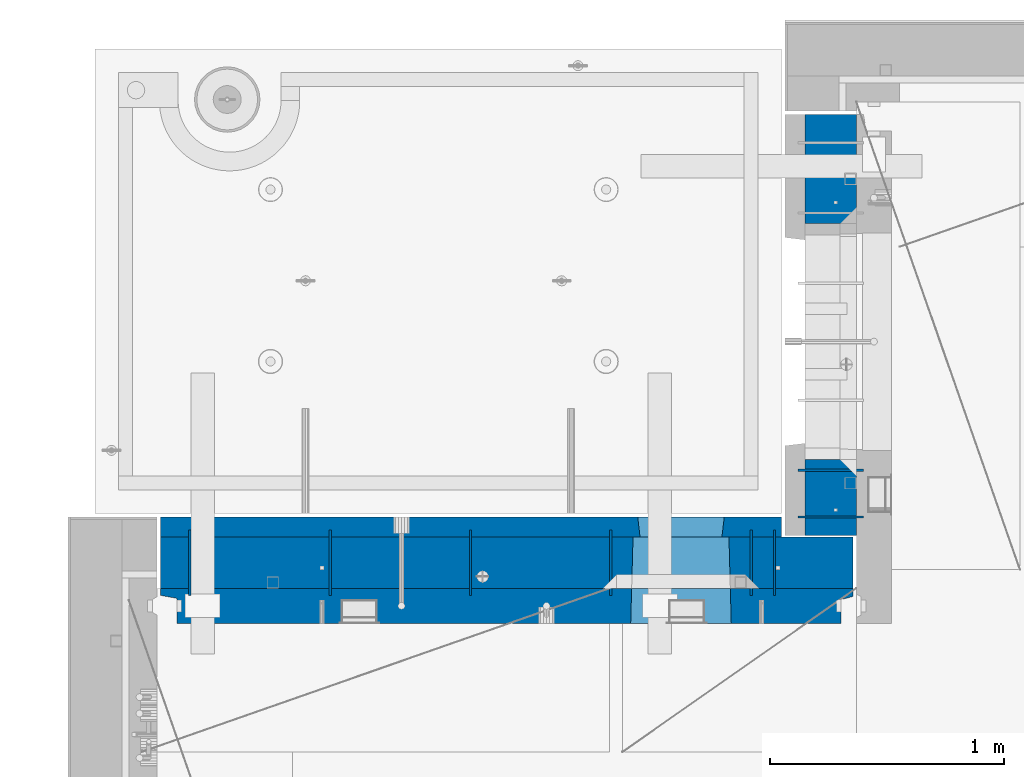
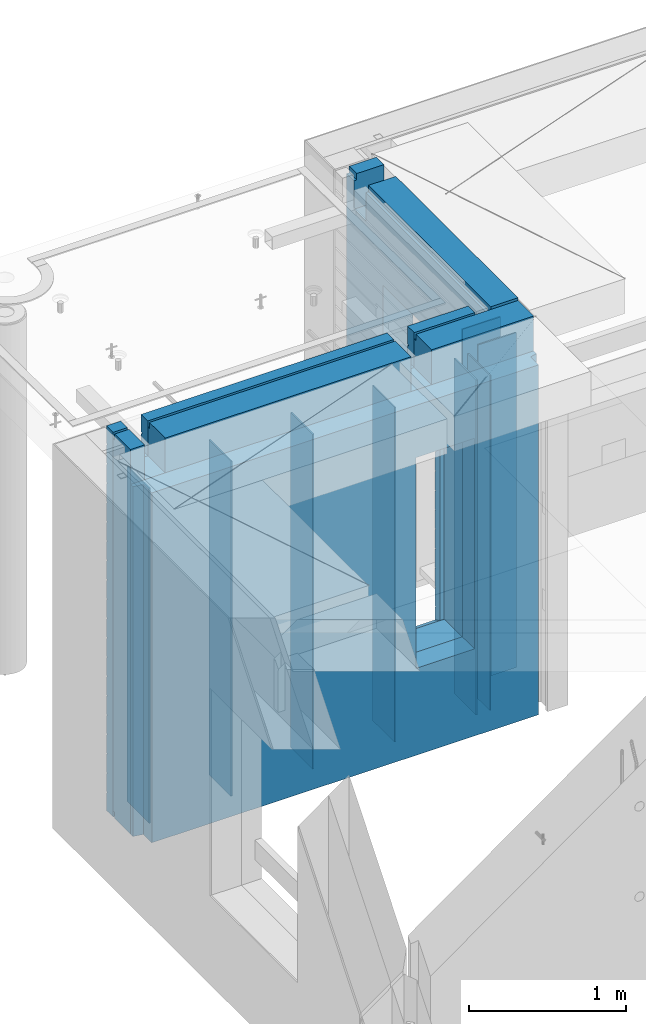
# One storey, part 236 of 350: 12 walls, 2 elements without a shape of their own.
"""IFC2X3 building model written with IfcOpenShell, lengths in millimetres."""

from ifc_helpers import new_model, si_unit, frame, origin_with_axes, place, context, subcontext, project, spatial, faceted_brep, material, type_object, element, aggregate, save


model = new_model("IFC2X3")

# Units and contexts
model_context = context("Model", 3, precision=1e-05, world=origin_with_axes())
body_context = subcontext(model_context, "Body", "Model", "MODEL_VIEW")
ifc_project = project(units=[si_unit("LENGTHUNIT", "METRE", prefix="MILLI"), si_unit("AREAUNIT", "SQUARE_METRE"), si_unit("VOLUMEUNIT", "CUBIC_METRE"), si_unit("MASSUNIT", "GRAM", prefix="KILO"), si_unit("TIMEUNIT", "SECOND"), si_unit("PLANEANGLEUNIT", "RADIAN"), si_unit("SOLIDANGLEUNIT", "STERADIAN"), si_unit("THERMODYNAMICTEMPERATUREUNIT", "DEGREE_CELSIUS"), si_unit("LUMINOUSINTENSITYUNIT", "LUMEN")], contexts=[model_context])

# Site, building, storey
site_placement = place(None, origin_with_axes())
site = spatial("IfcSite", under=ifc_project, at=site_placement, CompositionType="ELEMENT")
building_placement = place(site_placement, origin_with_axes())
building = spatial("IfcBuilding", under=site, at=building_placement, CompositionType="ELEMENT")
storey_placement = place(building_placement, origin_with_axes())
storey = spatial("IfcBuildingStorey", under=building, at=storey_placement, Name="2", CompositionType="ELEMENT", Elevation=0.0)

# Assembly, wall
assembly_1_placement = place(storey_placement, origin_with_axes())
assembly_1 = element("IfcElementAssembly", 1, at=assembly_1_placement, inside=storey, AssemblyPlace="NOTDEFINED", PredefinedType="REINFORCEMENT_UNIT")
ifc_material_1 = material(Name="Undefined")
wall_type_1 = type_object("IfcWallType", PredefinedType="NOTDEFINED")
wall_1_placement = place(assembly_1_placement, frame((11020.0, 20885.0002441406, 86115.0), z_axis=(0.0, 0.0, 1.0), x_axis=(-1.0, 3.00000001838171e-08, 0.0)))
wall_1 = element("IfcWall", 2, at=wall_1_placement, type_object=wall_type_1, material=ifc_material_1, Name="(PD)", context=body_context, shape_type="Brep", body=[
    faceted_brep([(0.0, 5.0, -1300.0), (0.0, 5.0, 1300.0), (280.0, 5.0, 1300.0), (280.0, 5.0, -1300.0), (0.0, -5.0, 1300.0), (280.0, -5.0, 1300.0), (0.0, -5.0, -1300.0), (280.0, -5.0, -1300.0)], [[[0, 1, 2, 3]], [[1, 4, 5, 2]], [[4, 6, 7, 5]], [[6, 0, 3, 7]], [[5, 7, 3, 2]], [[6, 4, 1, 0]]]),
])

assembly_2_placement = place(storey_placement, origin_with_axes())
assembly_2 = element("IfcElementAssembly", 3, at=assembly_2_placement, inside=storey, AssemblyPlace="NOTDEFINED", PredefinedType="REINFORCEMENT_UNIT")
wall_2_placement = place(assembly_2_placement, frame((10640.0002441406, 20549.9951872276, 86115.0), z_axis=(0.0, 0.0, 1.0), x_axis=(0.0, 1.0, 0.0)))
wall_2 = element("IfcWall", 4, at=wall_2_placement, type_object=wall_type_1, material=ifc_material_1, Name="(PD)", context=body_context, shape_type="Brep", body=[
    faceted_brep([(0.0, 5.0, -1300.0), (0.0, 5.0, 1300.0), (280.0, 5.0, 1300.0), (280.0, 5.0, -1300.0), (0.0, -5.0, 1300.0), (280.0, -5.0, 1300.0), (0.0, -5.0, -1300.0), (280.0, -5.0, -1300.0)], [[[0, 1, 2, 3]], [[1, 4, 5, 2]], [[4, 6, 7, 5]], [[6, 0, 3, 7]], [[5, 7, 3, 2]], [[6, 4, 1, 0]]]),
])

# Wall
wall_3_placement = place(assembly_1_placement, frame((11020.0, 21085.0002441406, 86115.0), z_axis=(0.0, 0.0, 1.0), x_axis=(-1.0, 3.00000001838171e-08, 0.0)))
wall_3 = element("IfcWall", 5, at=wall_3_placement, type_object=wall_type_1, material=ifc_material_1, Name="(PD)", context=body_context, shape_type="Brep", body=[
    faceted_brep([(0.0, 5.0, -1300.0), (0.0, 5.0, 1300.0), (280.0, 5.0, 1300.0), (280.0, 5.0, -1300.0), (0.0, -5.0, 1300.0), (280.0, -5.0, 1300.0), (0.0, -5.0, -1300.0), (280.0, -5.0, -1300.0)], [[[0, 1, 2, 3]], [[1, 4, 5, 2]], [[4, 6, 7, 5]], [[6, 0, 3, 7]], [[5, 7, 3, 2]], [[6, 4, 1, 0]]]),
])

wall_4_placement = place(assembly_2_placement, frame((8140.00024414063, 20549.9951872276, 86115.0), z_axis=(0.0, 0.0, 1.0), x_axis=(0.0, 1.0, 0.0)))
wall_4 = element("IfcWall", 6, at=wall_4_placement, type_object=wall_type_1, material=ifc_material_1, Name="(PD)", context=body_context, shape_type="Brep", body=[
    faceted_brep([(0.0, 5.0, -1300.0), (0.0, 5.0, 1300.0), (280.0, 5.0, 1300.0), (280.0, 5.0, -1300.0), (0.0, -5.0, 1300.0), (280.0, -5.0, 1300.0), (0.0, -5.0, -1300.0), (280.0, -5.0, -1300.0)], [[[0, 1, 2, 3]], [[1, 4, 5, 2]], [[4, 6, 7, 5]], [[6, 0, 3, 7]], [[5, 7, 3, 2]], [[6, 4, 1, 0]]]),
])

wall_5_placement = place(assembly_2_placement, frame((8740.00024414063, 20549.9951872276, 86115.0), z_axis=(0.0, 0.0, 1.0), x_axis=(0.0, 1.0, 0.0)))
wall_5 = element("IfcWall", 7, at=wall_5_placement, type_object=wall_type_1, material=ifc_material_1, Name="(PD)", context=body_context, shape_type="Brep", body=[
    faceted_brep([(0.0, 5.0, -1300.0), (0.0, 5.0, 1300.0), (280.0, 5.0, 1300.0), (280.0, 5.0, -1300.0), (0.0, -5.0, 1300.0), (280.0, -5.0, 1300.0), (0.0, -5.0, -1300.0), (280.0, -5.0, -1300.0)], [[[0, 1, 2, 3]], [[1, 4, 5, 2]], [[4, 6, 7, 5]], [[6, 0, 3, 7]], [[5, 7, 3, 2]], [[6, 4, 1, 0]]]),
])

wall_6_placement = place(assembly_2_placement, frame((9340.00024414063, 20549.9951872276, 86115.0), z_axis=(0.0, 0.0, 1.0), x_axis=(0.0, 1.0, 0.0)))
wall_6 = element("IfcWall", 8, at=wall_6_placement, type_object=wall_type_1, material=ifc_material_1, Name="(PD)", context=body_context, shape_type="Brep", body=[
    faceted_brep([(0.0, 5.0, -1300.0), (0.0, 5.0, 1300.0), (280.0, 5.0, 1300.0), (280.0, 5.0, -1300.0), (0.0, -5.0, 1300.0), (280.0, -5.0, 1300.0), (0.0, -5.0, -1300.0), (280.0, -5.0, -1300.0)], [[[0, 1, 2, 3]], [[1, 4, 5, 2]], [[4, 6, 7, 5]], [[6, 0, 3, 7]], [[5, 7, 3, 2]], [[6, 4, 1, 0]]]),
])

wall_7_placement = place(assembly_2_placement, frame((9940.00024414063, 20549.9951872276, 86115.0), z_axis=(0.0, 0.0, 1.0), x_axis=(0.0, 1.0, 0.0)))
wall_7 = element("IfcWall", 9, at=wall_7_placement, type_object=wall_type_1, material=ifc_material_1, Name="(PD)", context=body_context, shape_type="Brep", body=[
    faceted_brep([(0.0, 5.0, -1300.0), (0.0, 5.0, 1300.0), (280.0, 5.0, 1300.0), (280.0, 5.0, -1300.0), (0.0, -5.0, 1300.0), (280.0, -5.0, 1300.0), (0.0, -5.0, -1300.0), (280.0, -5.0, -1300.0)], [[[0, 1, 2, 3]], [[1, 4, 5, 2]], [[4, 6, 7, 5]], [[6, 0, 3, 7]], [[5, 7, 3, 2]], [[6, 4, 1, 0]]]),
])

wall_8_placement = place(assembly_2_placement, frame((10540.0002441406, 20549.9951872276, 86115.0), z_axis=(0.0, 0.0, 1.0), x_axis=(0.0, 1.0, 0.0)))
wall_8 = element("IfcWall", 10, at=wall_8_placement, type_object=wall_type_1, material=ifc_material_1, Name="(PD)", context=body_context, shape_type="Brep", body=[
    faceted_brep([(0.0, 5.0, -1300.0), (0.0, 5.0, 1300.0), (280.0, 5.0, 1300.0), (280.0, 5.0, -1300.0), (0.0, -5.0, 1300.0), (280.0, -5.0, 1300.0), (0.0, -5.0, -1300.0), (280.0, -5.0, -1300.0)], [[[0, 1, 2, 3]], [[1, 4, 5, 2]], [[4, 6, 7, 5]], [[6, 0, 3, 7]], [[5, 7, 3, 2]], [[6, 4, 1, 0]]]),
])

ifc_material_2 = material(Name="COS5gt")
wall_type_2 = type_object("IfcWallType", PredefinedType="NOTDEFINED")
wall_9_placement = place(assembly_1_placement, frame((10880.0, 20805.0, 86247.5), z_axis=(0.0, 0.0, 1.0), x_axis=(0.0, 1.0, 0.0)))
wall_9 = element("IfcWall", 11, at=wall_9_placement, type_object=wall_type_2, material=ifc_material_2, context=body_context, shape_type="Brep", body=[
    faceted_brep([(1800.0, -110.0, 1492.5), (1800.0, 90.0, 1492.5), (1705.0, 90.0, 1492.5), (1705.0, -110.0, 1492.5), (1800.0, 90.0, 1442.5), (1800.0, 110.0, 1442.5), (1705.0, 110.0, 1442.5), (1705.0, 90.0, 1442.5), (0.0, 110.0, 1442.5), (0.0, 90.0, 1442.5), (1555.0, 90.0, 1442.5), (1555.0, 110.0, 1442.5), (0.0, -110.0, -1492.5), (0.0, 90.0, -1492.5), (325.000271651108, 90.0, -1492.5), (325.000271651108, -110.0, -1492.5), (0.0, 90.0, -1442.5), (325.000271651108, 90.0, -1442.5), (0.0, -110.0, 1492.5), (0.0, 90.0, 1492.5), (0.0, 110.0, -1442.5), (325.000271651108, 110.0, -1442.5), (325.000271651108, 110.0, 857.5), (325.000271651108, -110.0, 857.5), (1335.00027165111, 110.0, 857.5), (1335.00027165111, -110.0, 857.5), (1555.0, 110.0, 1222.5), (1705.0, 110.0, 1222.5), (1800.0, 110.0, -1442.5), (1335.00027165111, 110.0, -1442.5), (1800.0, 90.0, -1442.5), (1800.0, 90.0, -1492.5), (1335.00027165111, 90.0, -1492.5), (1335.00027165111, 90.0, -1442.5), (1800.0, -110.0, -1492.5), (1335.00027165111, -110.0, -1492.5), (1705.0, -110.0, 1222.5), (1555.0, -110.0, 1222.5), (1555.0, -110.0, 1492.5), (1555.0, 90.0, 1492.5)], [[[0, 1, 2, 3]], [[4, 5, 6, 7]], [[8, 9, 10, 11]], [[12, 13, 14, 15]], [[13, 16, 17, 14]], [[13, 12, 18, 19, 9, 8, 20, 16]], [[16, 20, 21, 17]], [[15, 14, 17, 21, 22, 23]], [[23, 22, 24, 25]], [[21, 20, 8, 11, 26, 27, 6, 5, 28, 29, 24, 22]], [[30, 31, 32, 33]], [[28, 30, 33, 29]], [[5, 4, 1, 0, 34, 31, 30, 28]], [[31, 34, 35, 32]], [[25, 24, 29, 33, 32, 35]], [[34, 0, 3, 36, 37, 38, 18, 12, 15, 23, 25, 35]], [[19, 18, 38, 39]], [[9, 19, 39, 10]], [[38, 37, 26, 11, 10, 39]], [[36, 27, 26, 37]], [[3, 2, 7, 6, 27, 36]], [[1, 4, 7, 2]]]),
])

aggregate(assembly_1, [wall_1, wall_3, wall_9])

wall_10_placement = place(assembly_2_placement, frame((8000.0, 20689.9951872276, 86247.5), z_axis=(0.0, 0.0, 1.0), x_axis=(1.0, 0.0, 0.0)))
wall_10 = element("IfcWall", 12, at=wall_10_placement, type_object=wall_type_2, material=ifc_material_2, context=body_context, shape_type="Brep", body=[
    faceted_brep([(2075.0, 110.0, 1442.5), (2075.0, 90.0, 1442.5), (2075.0, 90.0, 1492.5), (2075.0, -110.0, 1492.5), (2075.0, -110.000000000004, 1222.5), (2075.0, 109.999999999996, 1222.5), (2225.0, -110.000000000004, 1222.5), (2225.0, 109.999999999996, 1222.5), (2225.0, 110.0, 1442.5), (2225.0, -110.0, 1492.5), (2225.0, 90.0, 1492.5), (2225.0, 90.0, 1442.5), (2975.0, 90.0, -1492.5), (15.0, 90.0, -1492.5), (15.0, 90.0, -1442.5), (2975.0, 90.0, -1442.5), (2975.0, -110.0, -1492.5), (15.0, -110.0, -1492.5), (15.0, 90.0, 1442.5), (15.0, 90.0, 1492.5), (119.999999999998, 90.0, 1492.5), (119.999999999998, 90.0, 1442.5), (15.0, -110.0, 1492.5), (119.999999999998, -110.0, 1492.5), (269.999999999998, 110.0, 1442.5), (269.999999999998, 90.0, 1442.5), (269.999999999998, 90.0, 1492.5), (269.999999999998, -110.0, 1492.5), (269.999999999998, 110.0, 1222.5), (269.999999999998, -110.0, 1222.5), (119.999999999998, 110.0, 1222.5), (119.999999999998, -110.0, 1222.5), (119.999999999998, 110.0, 1442.5), (15.0, 110.0, 1442.5), (15.0, 110.0, -1442.5), (2975.0, 110.0, -1442.5), (2975.0, 110.0, 1442.5), (2975.0, 90.0, 1442.5), (2975.0, 90.0, 1492.5), (2975.0, -110.0, 1492.5), (2029.05276420954, -110.0, -813.445945945947), (2029.05276420954, -110.0, 813.445945945947), (2450.94465610143, -110.0, 813.445945945947), (2450.94465610143, -110.0, -813.445945945947), (2034.99871015549, 110.0, -802.5), (2034.99871015549, 110.0, 807.5), (2034.99871015549, 110.0, -807.5), (2444.99871015549, 110.0, -807.5), (2414.99871015549, 110.0, -807.5), (2064.99871015549, 110.0, -807.5), (2444.99871015549, 110.0, 807.5), (2444.99871015549, 110.0, -802.5)], [[[0, 1, 2, 3, 4, 5]], [[5, 4, 6, 7]], [[8, 7, 6, 9, 10, 11]], [[12, 13, 14, 15]], [[16, 17, 13, 12]], [[18, 19, 20, 21]], [[19, 22, 23, 20]], [[24, 25, 1, 0]], [[26, 27, 3, 2]], [[25, 26, 2, 1]], [[24, 28, 29, 27, 26, 25]], [[30, 31, 29, 28]], [[32, 21, 20, 23, 31, 30]], [[33, 18, 21, 32]], [[13, 17, 22, 19, 18, 33, 34, 14]], [[35, 15, 14, 34]], [[36, 37, 38, 39, 16, 12, 15, 35]], [[37, 36, 8, 11]], [[38, 37, 11, 10]], [[39, 38, 10, 9]], [[4, 3, 27, 29, 31, 23, 22, 17, 16, 39, 9, 6], [40, 41, 42, 43]], [[44, 45, 41, 40, 46]], [[43, 47, 48, 49, 46, 40]], [[42, 50, 51, 47, 43]], [[41, 45, 50, 42]], [[36, 35, 34, 33, 32, 30, 28, 24, 0, 5, 7, 8], [44, 46, 49, 48, 47, 51, 50, 45]]]),
])

ifc_material_3 = material(Name="CONCRETE/C30/37")
wall_type_3 = type_object("IfcWallType", PredefinedType="NOTDEFINED")
wall_11_placement = place(assembly_2_placement, frame((8000.0, 20842.4951872276, 86247.5), z_axis=(0.0, 0.0, 1.0), x_axis=(1.0, 0.0, 0.0)))
wall_11 = element("IfcWall", 13, at=wall_11_placement, type_object=wall_type_3, material=ifc_material_3, context=body_context, shape_type="Brep", body=[
    faceted_brep([(15.0, 32.4999992506928, 1344.9999999992), (15.0, 32.4999991126933, 1355.00000040043), (119.999999999998, 32.4999991126933, 1355.00000040043), (119.999999999998, 32.4999992506928, 1344.9999999992), (15.0, 42.5, 1342.99999994476), (119.999999999998, 42.4999999843276, 1342.99999994476), (2670.0, 42.5, -1492.5), (15.0, 42.5, -1492.5), (15.0, 42.5, -1357.00000005524), (2670.0, 42.5, -1357.00000005524), (15.0, 32.4999992506928, -1355.0000000008), (2670.0, 32.4999992506928, -1355.0000000008), (15.0, 32.4999991126933, -1344.99999959957), (2670.0, 32.4999991126933, -1344.99999959957), (2670.0, 42.4999992431622, -1343.00000011075), (15.0, 42.5, -1343.00000011075), (15.0, 42.5, -1207.00000005524), (2670.0, 42.4999992794619, -1207.00000005524), (15.0, 32.4999992506928, -1205.0000000008), (2670.0, 32.4999992506928, -1205.0000000008), (15.0, 32.4999991126933, -1194.99999959957), (2670.0, 32.4999991126933, -1194.99999959957), (2670.0, 42.4999992431622, -1193.00000011075), (15.0, 42.5, -1193.00000011075), (15.0, 42.5, -1057.00000005524), (2670.0, 42.4999992814919, -1057.00000005524), (15.0, 32.4999992506928, -1055.0000000008), (2670.0, 32.4999992506928, -1055.0000000008), (15.0, 32.4999991126933, -1044.99999959957), (2670.0, 32.4999991126933, -1044.99999959957), (2670.0, 42.4999992431622, -1043.00000011075), (15.0, 42.5, -1043.00000011075), (15.0, 42.5, -907.000000055239), (2670.0, 42.4999992837584, -907.000000055239), (15.0000000000009, 32.4999992506928, -905.0000000008), (2670.0, 32.4999992506928, -905.0000000008), (15.0000000000009, 32.4999991126933, -894.999999599575), (2670.0, 32.4999991126933, -894.999999599575), (2670.0, 42.4999992431622, -893.000000110755), (15.0, 42.5, -893.000000110755), (2670.0, 42.4999992431622, 756.999999889245), (2670.0, 32.4999991126933, 755.000000400425), (2423.82223946286, 32.4999991126933, 755.000000400425), (2424.99871015549, 42.4999993130041, 756.999999889245), (2670.0, 32.4999992506928, 744.9999999992), (2423.8222394791, 32.4999992506928, 744.9999999992), (2670.0, 42.4999993594029, 742.999999944761), (2424.99871015549, 42.4999994185164, 742.999999944761), (2670.0, 42.4999992431622, 606.999999889245), (2424.99871015549, 42.4999993130041, 606.999999889245), (2670.0, 32.4999991126933, 605.000000400425), (2423.82223946286, 32.4999991126933, 605.000000400425), (2670.0, 32.4999992506928, 594.9999999992), (2423.8222394791, 32.4999992506928, 594.9999999992), (2670.0, 42.4999993425627, 592.999999944761), (2424.99871015549, 42.4999994032296, 592.999999944761), (2670.0, 42.4999992431622, 456.999999889245), (2424.99871015549, 42.4999993130041, 456.999999889245), (2670.0, 32.4999991126933, 455.000000400425), (2423.82223946286, 32.4999991126933, 455.000000400425), (2670.0, 32.4999992506928, 444.9999999992), (2423.8222394791, 32.4999992506928, 444.9999999992), (2670.0, 42.4999993299862, 442.999999944761), (2424.99871015549, 42.4999993918136, 442.999999944761), (2670.0, 42.4999992431622, 306.999999889245), (2424.99871015549, 42.4999993130041, 306.999999889245), (2670.0, 32.4999991126933, 305.000000400425), (2423.82223946286, 32.4999991126933, 305.000000400425), (2670.0, 32.4999992506928, 294.9999999992), (2423.8222394791, 32.4999992506928, 294.9999999992), (2670.0, 42.4999993202327, 292.999999944761), (2424.99871015549, 42.4999993829624, 292.999999944761), (2670.0, 42.4999992431622, 156.999999889245), (2424.99871015549, 42.4999993130041, 156.999999889245), (2670.0, 32.4999991126933, 155.000000400425), (2423.82223946286, 32.4999991126933, 155.000000400425), (2670.0, 32.4999992506928, 144.9999999992), (2423.8222394791, 32.4999992506928, 144.9999999992), (2670.0, 42.4999993124511, 142.999999944761), (2424.99871015549, 42.4999993758975, 142.999999944761), (2670.0, 42.4999992431622, 6.99999988924537), (2424.99871015549, 42.4999993130041, 6.99999988924537), (2670.0, 32.4999991126933, 5.00000040042505), (2423.82223946286, 32.4999991126933, 5.00000040042505), (2670.0, 32.4999992506928, -5.00000000080036), (2423.8222394791, 32.4999992506928, -5.00000000080036), (2670.0, 42.4999993060956, -7.00000005523907), (2424.99871015549, 42.4999993701276, -7.00000005523907), (2670.0, 42.4999992431622, -143.000000110755), (2424.99871015549, 42.4999993130041, -143.000000110755), (2670.0, 32.4999991126933, -144.999999599575), (2423.82223946286, 32.4999991126933, -144.999999599575), (2670.0, 32.4999992506928, -155.0000000008), (2423.8222394791, 32.4999992506928, -155.0000000008), (2670.0, 42.4999993008096, -157.000000055239), (2424.99871015549, 42.4999993653291, -157.000000055239), (2670.0, 42.4999992431622, -293.000000110755), (2424.99871015549, 42.4999993130041, -293.000000110755), (2670.0, 32.4999991126933, -294.999999599575), (2423.82223946286, 32.4999991126933, -294.999999599575), (2670.0, 32.4999992506928, -305.0000000008), (2423.8222394791, 32.4999992506928, -305.0000000008), (2670.0, 42.4999992963421, -307.000000055239), (2424.99871015549, 42.4999993612764, -307.000000055239), (2670.0, 42.4999992431622, -443.000000110755), (2424.99871015549, 42.4999993130041, -443.000000110755), (2670.0, 32.4999991126933, -444.999999599575), (2423.82223946286, 32.4999991126933, -444.999999599575), (2670.0, 32.4999992506928, -455.0000000008), (2423.8222394791, 32.4999992506928, -455.0000000008), (2670.0, 42.4999992925186, -457.000000055239), (2424.99871015549, 42.4999993578058, -457.000000055239), (2670.0, 42.4999992431622, -593.000000110755), (2424.99871015549, 42.4999993130041, -593.000000110755), (2670.0, 32.4999991126933, -594.999999599575), (2423.82223946286, 32.4999991126933, -594.999999599575), (2670.0, 32.4999992506928, -605.0000000008), (2423.8222394791, 32.4999992506928, -605.0000000008), (2670.0, 42.4999992892044, -607.000000055239), (2424.99871015549, 42.4999993547972, -607.000000055239), (2670.0, 42.4999992431622, -743.000000110755), (2424.99871015549, 42.4999993130041, -743.000000110755), (2670.0, 32.4999991126933, -744.999999599575), (2423.82223946286, 32.4999991126933, -744.999999599575), (2670.0, 32.4999992506928, -755.0000000008), (2423.8222394791, 32.4999992506928, -755.0000000008), (2670.0, 42.4999992863086, -757.000000055239), (2424.99871015549, 42.4999993521669, -757.000000055239), (2054.99871015549, 42.5, -857.5), (2064.99871015549, -42.5, -807.5), (2414.99871015549, -42.5, -807.5), (2424.99871015549, 42.5, -857.5), (2414.99871015549, -42.5, 782.5), (2414.99871015549, -42.5, 787.5), (2424.99871015549, 42.5, 782.5), (15.0, 42.5, -757.000000055239), (2054.99871015549, 42.4999994516256, -757.000000055239), (15.0, 32.4999992506928, -755.0000000008), (2056.17518083188, 32.4999992506928, -755.0000000008), (15.0, 32.4999991126933, -744.999999599575), (2056.17518084811, 32.4999991126933, -744.999999599575), (15.0, 42.5, -743.000000110755), (2054.99871015549, 42.4999994184764, -743.000000110755), (15.0, 42.5, -607.000000055239), (2054.99871015549, 42.4999994538521, -607.000000055239), (15.0, 32.4999992506928, -605.0000000008), (2056.17518083188, 32.4999992506928, -605.0000000008), (15.0, 32.4999991126933, -594.999999599575), (2056.17518084811, 32.4999991126933, -594.999999599575), (15.0, 42.5, -593.000000110755), (2054.99871015549, 42.4999994184764, -593.000000110755), (15.0, 42.5, -457.000000055239), (2054.99871015549, 42.4999994563987, -457.000000055239), (15.0000000000009, 32.4999992506928, -455.0000000008), (2056.17518083188, 32.4999992506928, -455.0000000008), (15.0000000000009, 32.4999991126933, -444.999999599575), (2056.17518084811, 32.4999991126933, -444.999999599575), (15.0, 42.5, -443.000000110755), (2054.99871015549, 42.4999994184764, -443.000000110755), (15.0, 42.5, -307.000000055239), (2054.99871015549, 42.4999994593381, -307.000000055239), (15.0, 32.4999992506928, -305.0000000008), (2056.17518083188, 32.4999992506928, -305.0000000008), (15.0, 32.4999991126933, -294.999999599575), (2056.17518084811, 32.4999991126933, -294.999999599575), (15.0, 42.5, -293.000000110755), (2054.99871015549, 42.4999994184764, -293.000000110755), (15.0, 42.5, -157.000000055239), (2054.99871015549, 42.4999994627688, -157.000000055239), (15.0000000000009, 32.4999992506928, -155.0000000008), (2056.17518083188, 32.4999992506928, -155.0000000008), (15.0000000000009, 32.4999991126933, -144.999999599575), (2056.17518084811, 32.4999991126933, -144.999999599575), (15.0, 42.5, -143.000000110755), (2054.99871015549, 42.4999994184764, -143.000000110755), (15.0, 42.5, -7.00000005523907), (2054.99871015549, 42.4999994668287, -7.00000005523907), (14.9999999999991, 32.4999992506928, -5.00000000080036), (2056.17518083188, 32.4999992506928, -5.00000000080036), (14.9999999999991, 32.4999991126933, 5.00000040042505), (2056.17518084811, 32.4999991126933, 5.00000040042505), (15.0, 42.5, 6.99999988924537), (2054.99871015549, 42.4999994184764, 6.99999988924537), (15.0, 42.5, 142.999999944761), (2054.99871015549, 42.4999994717145, 142.999999944761), (15.0000000000009, 32.4999992506928, 144.9999999992), (2056.17518083188, 32.4999992506928, 144.9999999992), (15.0000000000009, 32.4999991126933, 155.000000400425), (2056.17518084811, 32.4999991126933, 155.000000400425), (15.0, 42.5, 156.999999889245), (2054.99871015549, 42.4999994184764, 156.999999889245), (15.0, 42.5, 292.999999944761), (2054.99871015549, 42.4999994776954, 292.999999944761), (15.0, 32.4999992506928, 294.9999999992), (2056.17518083188, 32.4999992506928, 294.9999999992), (15.0, 32.4999991126933, 305.000000400425), (2056.17518084811, 32.4999991126933, 305.000000400425), (15.0, 42.5, 306.999999889245), (2054.99871015549, 42.4999994184764, 306.999999889245), (15.0, 42.5, 442.999999944761), (2054.99871015549, 42.499999485186, 442.999999944761), (15.0, 32.4999992506928, 444.9999999992), (2056.17518083188, 32.4999992506928, 444.9999999992), (15.0, 32.4999991126933, 455.000000400425), (2056.17518084811, 32.4999991126933, 455.000000400425), (15.0, 42.5, 456.999999889245), (2054.99871015549, 42.4999994184764, 456.999999889245), (15.0, 42.5, 592.999999944761), (2054.99871015549, 42.4999994948485, 592.999999944761), (15.0, 32.4999992506928, 594.9999999992), (2056.17518083188, 32.4999992506928, 594.9999999992), (15.0, 32.4999991126933, 605.000000400425), (2056.17518084811, 32.4999991126933, 605.000000400425), (15.0, 42.5, 606.999999889245), (2054.99871015549, 42.4999994184764, 606.999999889245), (15.0, 42.5, 742.999999944761), (2054.99871015549, 42.4999995077887, 742.999999944761), (15.0, 32.4999992506928, 744.9999999992), (2056.17518083188, 32.4999992506928, 744.9999999992), (15.0, 32.4999991126933, 755.000000400425), (2056.17518084811, 32.4999991126933, 755.000000400425), (15.0, 42.5, 756.999999889245), (2054.99871015549, 42.4999994184764, 756.999999889245), (2064.99871015549, -42.5, 782.5), (2054.99871015549, 42.5, 782.5), (2064.99871015549, -42.5, 787.5), (2064.99871015549, 42.5, 782.5), (2414.99871015549, 42.5, 782.5), (15.0, 42.5, 892.999999944761), (2670.0, 42.4999993831079, 892.999999944761), (15.0, 32.4999992506928, 894.9999999992), (2670.0, 32.4999992506928, 894.9999999992), (15.0, 32.4999991126933, 905.000000400425), (2670.0, 32.4999991126933, 905.000000400425), (2670.0, 42.4999992431622, 906.999999889245), (15.0, 42.5, 906.999999889245), (15.0, 42.5, 1042.99999994476), (2670.0, 42.4999994189602, 1042.99999994476), (15.0, 32.4999992506928, 1044.9999999992), (2670.0, 32.4999992506928, 1044.9999999992), (15.0, 32.4999991126933, 1055.00000040043), (2670.0, 32.4999991126933, 1055.00000040043), (2670.0, 42.4999992431622, 1056.99999988925), (15.0, 42.5, 1056.99999988925), (15.0, 42.5, 1192.99999994476), (2670.0, 42.4999994795107, 1192.99999994476), (15.0000000000009, 32.4999992506928, 1194.9999999992), (2670.0, 32.4999992506928, 1194.9999999992), (15.0000000000009, 32.4999991126933, 1205.00000040043), (2670.0, 32.4999991126933, 1205.00000040043), (2670.0, 42.4999992431622, 1206.99999988925), (15.0, 42.5, 1206.99999988925), (2670.0, -42.5, 1492.5), (2670.0, 42.5, 1492.5), (2225.0, 42.5, 1492.5), (2225.0, -42.5, 1492.5), (2670.0, 42.4999992431622, 1356.99999988925), (2225.0, 42.4999993700148, 1356.99999988925), (2670.0, 32.4999992506928, 1344.9999999992), (2670.0, 42.4999996036859, 1342.99999994476), (2225.0, 42.4999996701117, 1342.99999994476), (2225.0, 32.4999992506928, 1344.9999999992), (2670.0, 32.4999991126933, 1355.00000040043), (2225.0, 32.4999991126933, 1355.00000040043), (2670.0, -42.5, -1492.5), (15.0, -42.5, -1492.5), (15.0, -42.5, 1492.5), (15.0, 42.5, 1492.5), (15.0, 42.5, 1356.99999988925), (119.999999999998, -42.5, 1492.5), (119.999999999998, 42.5, 1492.5), (119.999999999998, 42.4999999700703, 1356.99999988925), (119.999999999998, -42.5, 1222.5), (119.999999999998, 42.4999999076099, 1222.5), (269.999999999998, -42.5, 1222.5), (269.999999999998, 42.4999998750354, 1222.5), (269.999999999998, 42.5, 1492.5), (269.999999999998, 42.4999999273095, 1356.99999988925), (269.999999999998, 32.4999991126933, 1355.00000040043), (269.999999999998, 32.4999992506928, 1344.9999999992), (269.999999999998, 42.4999999619358, 1342.99999994476), (269.999999999998, -42.5, 1492.5), (2075.0, 32.4999991126933, 1355.00000040043), (2075.0, 32.4999992506928, 1344.9999999992), (2075.0, 42.4999996925035, 1342.99999994476), (2075.0, 42.4999994593163, 1222.5), (2225.0, 42.4999994264763, 1222.5), (2075.0, -42.5000000000036, 1222.5), (2225.0, -42.5000000000036, 1222.5), (2075.0, -42.5, 1492.5), (2075.0, 42.5, 1492.5), (2075.0, 42.4999994127757, 1356.99999988925)], [[[0, 1, 2, 3]], [[4, 0, 3, 5]], [[6, 7, 8, 9]], [[9, 8, 10, 11]], [[11, 10, 12, 13]], [[14, 13, 12, 15]], [[14, 15, 16, 17]], [[17, 16, 18, 19]], [[19, 18, 20, 21]], [[22, 21, 20, 23]], [[22, 23, 24, 25]], [[25, 24, 26, 27]], [[27, 26, 28, 29]], [[30, 29, 28, 31]], [[30, 31, 32, 33]], [[33, 32, 34, 35]], [[35, 34, 36, 37]], [[38, 37, 36, 39]], [[40, 41, 42, 43]], [[41, 44, 45, 42]], [[44, 46, 47, 45]], [[46, 48, 49, 47]], [[48, 50, 51, 49]], [[50, 52, 53, 51]], [[52, 54, 55, 53]], [[54, 56, 57, 55]], [[56, 58, 59, 57]], [[58, 60, 61, 59]], [[60, 62, 63, 61]], [[62, 64, 65, 63]], [[64, 66, 67, 65]], [[66, 68, 69, 67]], [[68, 70, 71, 69]], [[70, 72, 73, 71]], [[72, 74, 75, 73]], [[74, 76, 77, 75]], [[76, 78, 79, 77]], [[78, 80, 81, 79]], [[80, 82, 83, 81]], [[82, 84, 85, 83]], [[84, 86, 87, 85]], [[86, 88, 89, 87]], [[88, 90, 91, 89]], [[90, 92, 93, 91]], [[92, 94, 95, 93]], [[94, 96, 97, 95]], [[96, 98, 99, 97]], [[98, 100, 101, 99]], [[100, 102, 103, 101]], [[102, 104, 105, 103]], [[104, 106, 107, 105]], [[106, 108, 109, 107]], [[108, 110, 111, 109]], [[110, 112, 113, 111]], [[112, 114, 115, 113]], [[114, 116, 117, 115]], [[116, 118, 119, 117]], [[118, 120, 121, 119]], [[120, 122, 123, 121]], [[122, 124, 125, 123]], [[124, 126, 127, 125]], [[128, 129, 130, 131]], [[43, 42, 45, 47, 49, 51, 53, 55, 57, 59, 61, 63, 65, 67, 69, 71, 73, 75, 77, 79, 81, 83, 85, 87, 89, 91, 93, 95, 97, 99, 101, 103, 105, 107, 109, 111, 113, 115, 117, 119, 121, 123, 125, 127, 131, 130, 132, 133, 134]], [[126, 38, 39, 135, 136, 128, 131, 127]], [[135, 137, 138, 136]], [[137, 139, 140, 138]], [[139, 141, 142, 140]], [[141, 143, 144, 142]], [[143, 145, 146, 144]], [[145, 147, 148, 146]], [[147, 149, 150, 148]], [[149, 151, 152, 150]], [[151, 153, 154, 152]], [[153, 155, 156, 154]], [[155, 157, 158, 156]], [[157, 159, 160, 158]], [[159, 161, 162, 160]], [[161, 163, 164, 162]], [[163, 165, 166, 164]], [[165, 167, 168, 166]], [[167, 169, 170, 168]], [[169, 171, 172, 170]], [[171, 173, 174, 172]], [[173, 175, 176, 174]], [[175, 177, 178, 176]], [[177, 179, 180, 178]], [[179, 181, 182, 180]], [[181, 183, 184, 182]], [[183, 185, 186, 184]], [[185, 187, 188, 186]], [[187, 189, 190, 188]], [[189, 191, 192, 190]], [[191, 193, 194, 192]], [[193, 195, 196, 194]], [[195, 197, 198, 196]], [[197, 199, 200, 198]], [[199, 201, 202, 200]], [[201, 203, 204, 202]], [[203, 205, 206, 204]], [[205, 207, 208, 206]], [[207, 209, 210, 208]], [[209, 211, 212, 210]], [[211, 213, 214, 212]], [[213, 215, 216, 214]], [[215, 217, 218, 216]], [[217, 219, 220, 218]], [[219, 221, 222, 220]], [[223, 129, 128, 136, 138, 140, 142, 144, 146, 148, 150, 152, 154, 156, 158, 160, 162, 164, 166, 168, 170, 172, 174, 176, 178, 180, 182, 184, 186, 188, 190, 192, 194, 196, 198, 200, 202, 204, 206, 208, 210, 212, 214, 216, 218, 220, 222, 224, 225]], [[226, 227, 134, 133, 225, 224]], [[226, 224, 222, 221, 228, 229, 40, 43, 134, 227]], [[229, 228, 230, 231]], [[231, 230, 232, 233]], [[234, 233, 232, 235]], [[234, 235, 236, 237]], [[237, 236, 238, 239]], [[239, 238, 240, 241]], [[242, 241, 240, 243]], [[242, 243, 244, 245]], [[245, 244, 246, 247]], [[247, 246, 248, 249]], [[250, 249, 248, 251]], [[252, 253, 254, 255]], [[253, 256, 257, 254]], [[258, 259, 260, 261]], [[262, 258, 261, 263]], [[256, 262, 263, 257]], [[253, 252, 264, 6, 9, 11, 13, 14, 17, 19, 21, 22, 25, 27, 29, 30, 33, 35, 37, 38, 126, 124, 122, 120, 118, 116, 114, 112, 110, 108, 106, 104, 102, 100, 98, 96, 94, 92, 90, 88, 86, 84, 82, 80, 78, 76, 74, 72, 70, 68, 66, 64, 62, 60, 58, 56, 54, 52, 50, 48, 46, 44, 41, 40, 229, 231, 233, 234, 237, 239, 241, 242, 245, 247, 249, 250, 259, 258, 262, 256]], [[265, 7, 6, 264]], [[0, 4, 251, 248, 246, 244, 243, 240, 238, 236, 235, 232, 230, 228, 221, 219, 217, 215, 213, 211, 209, 207, 205, 203, 201, 199, 197, 195, 193, 191, 189, 187, 185, 183, 181, 179, 177, 175, 173, 171, 169, 167, 165, 163, 161, 159, 157, 155, 153, 151, 149, 147, 145, 143, 141, 139, 137, 135, 39, 36, 34, 32, 31, 28, 26, 24, 23, 20, 18, 16, 15, 12, 10, 8, 7, 265, 266, 267, 268, 1]], [[267, 266, 269, 270]], [[268, 267, 270, 271]], [[1, 268, 271, 2]], [[270, 269, 272, 273, 5, 3, 2, 271]], [[273, 272, 274, 275]], [[276, 277, 278, 279, 280, 275, 274, 281]], [[279, 278, 282, 283]], [[280, 279, 283, 284]], [[259, 250, 251, 4, 5, 273, 275, 280, 284, 285, 286, 260]], [[285, 287, 288, 286]], [[254, 257, 263, 261, 260, 286, 288, 255]], [[287, 289, 281, 274, 272, 269, 266, 265, 264, 252, 255, 288], [130, 129, 223, 225, 133, 132]], [[276, 281, 289, 290]], [[277, 276, 290, 291]], [[278, 277, 291, 282]], [[290, 289, 287, 285, 284, 283, 282, 291]]]),
])

ifc_material_4 = material(Name="CONCRETE/C25/30")
wall_type_4 = type_object("IfcWallType", PredefinedType="NOTDEFINED")
wall_12_placement = place(assembly_2_placement, frame((8000.0, 20504.9951872276, 86112.5), z_axis=(0.0, 0.0, 1.0), x_axis=(1.0, 0.0, 0.0)))
wall_12 = element("IfcWall", 14, at=wall_12_placement, type_object=wall_type_4, material=ifc_material_4, context=body_context, shape_type="Brep", body=[
    faceted_brep([(2925.0, -75.0, 1357.5), (2925.0, -75.0, -1357.5), (2925.0, 27.0, -1357.5), (2925.0, 27.0, 1357.5), (2975.0, 75.0, 1357.5), (15.0, 75.0, 1357.5), (15.0, 45.0, 1357.5), (85.0, 32.0, 1357.5), (85.0, -75.0, 1357.5), (2975.0, 40.0, 1357.5), (85.0, 32.0, -1357.5), (85.0, -75.0, -1357.5), (15.0, 45.0, -1357.5), (15.0, 75.0, -1357.5), (2975.0, 75.0, -1357.5), (2975.0, 40.0, -1357.5), (2024.99871015549, -75.0, 952.5), (2029.05276420954, 75.0, 948.445945945947), (2450.94465610143, 75.0, 948.445945945947), (2454.99871015549, -75.0, 952.5), (2029.05276420954, 75.0, -678.445945945947), (2450.94465610143, 75.0, -678.445945945947), (2454.99871015549, -75.0, -682.5), (2024.99871015549, -75.0, -682.5)], [[[0, 1, 2, 3]], [[4, 5, 6, 7, 8, 0, 3, 9]], [[7, 10, 11, 8]], [[6, 12, 10, 7]], [[5, 13, 12, 6]], [[1, 11, 10, 12, 13, 14, 15, 2]], [[9, 3, 2, 15]], [[14, 4, 9, 15]], [[16, 17, 18, 19]], [[13, 5, 4, 14], [20, 21, 18, 17]], [[19, 18, 21, 22]], [[8, 11, 1, 0], [23, 16, 19, 22]], [[17, 16, 23, 20]], [[22, 21, 20, 23]]]),
])

aggregate(assembly_2, [wall_2, wall_4, wall_5, wall_6, wall_7, wall_8, wall_11, wall_10, wall_12])

save(model, "model.ifc")
